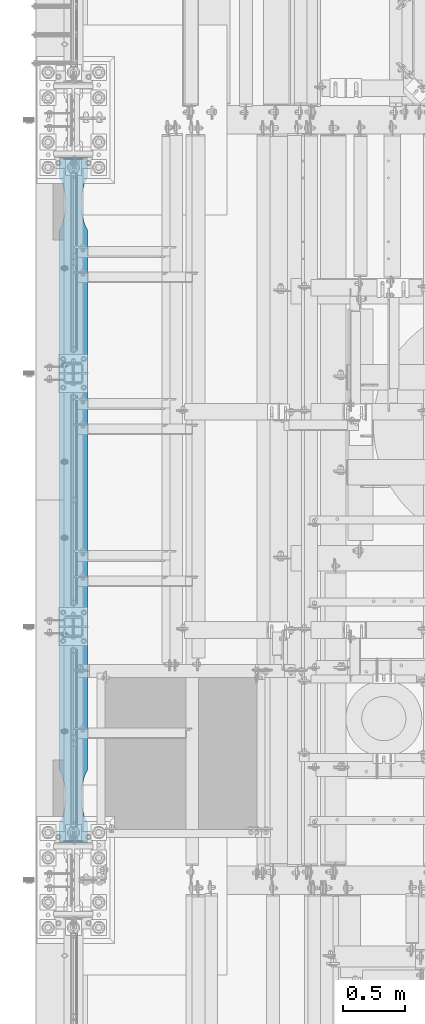
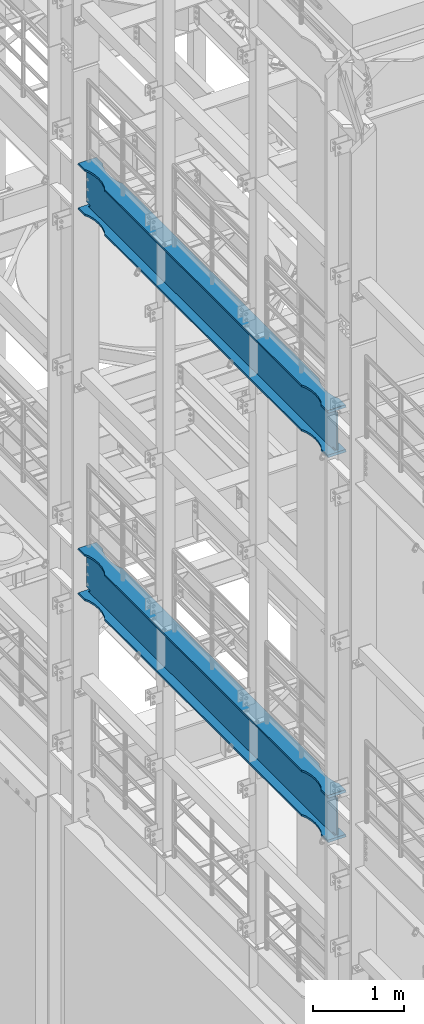
# One storey, part 1021 of 1876: 2 beams, 2 elements without a shape of their own.
"""IFC2X3 building model written with IfcOpenShell, lengths in millimetres."""

from ifc_helpers import new_model, si_unit, frame, origin_with_axes, place, context, subcontext, project, spatial, faceted_brep, material, type_object, element, aggregate, save


model = new_model("IFC2X3")

# Units and contexts
model_context = context("Model", 3, precision=1e-05, world=origin_with_axes())
body_context = subcontext(model_context, "Body", "Model", "MODEL_VIEW")
ifc_project = project(units=[si_unit("LENGTHUNIT", "METRE", prefix="MILLI"), si_unit("AREAUNIT", "SQUARE_METRE"), si_unit("VOLUMEUNIT", "CUBIC_METRE"), si_unit("MASSUNIT", "GRAM", prefix="KILO"), si_unit("TIMEUNIT", "SECOND"), si_unit("PLANEANGLEUNIT", "RADIAN"), si_unit("SOLIDANGLEUNIT", "STERADIAN"), si_unit("THERMODYNAMICTEMPERATUREUNIT", "DEGREE_CELSIUS"), si_unit("LUMINOUSINTENSITYUNIT", "LUMEN")], contexts=[model_context])

# Site, building, storey
site_placement = place(None, origin_with_axes())
site = spatial("IfcSite", under=ifc_project, at=site_placement, CompositionType="ELEMENT")
building_placement = place(site_placement, origin_with_axes())
building = spatial("IfcBuilding", under=site, at=building_placement, Name="Undefined", CompositionType="ELEMENT")
storey_placement = place(building_placement, origin_with_axes())
storey = spatial("IfcBuildingStorey", under=building, at=storey_placement, Name="Undefined", CompositionType="ELEMENT", Elevation=0.0)

# Assembly, beam
assembly_1_placement = place(storey_placement, origin_with_axes())
assembly_1 = element("IfcElementAssembly", 1, at=assembly_1_placement, inside=storey, Name="BEAM", AssemblyPlace="NOTDEFINED", PredefinedType="RIGID_FRAME")
ifc_material = material(Name="STEEL/A992")
beam_type = type_object("IfcBeamType", Name="W24X103", PredefinedType="NOTDEFINED")
beam_1_placement = place(assembly_1_placement, frame((0.0, 1524.0, 12998.45), z_axis=(0.0, 0.0, 1.0), x_axis=(0.0, 1.0, 0.0)))
beam_1 = element("IfcBeam", 2, at=beam_1_placement, type_object=beam_type, material=ifc_material, Name="BEAM", ObjectType="W24X103", context=body_context, shape_type="Brep", body=[
    faceted_brep([(306.3875, 7.14375, -250.825000000001), (298.45, -7.14375, -250.825000000001), (298.45, -7.14375, 250.825000000001), (306.3875, 7.14375, 250.825000000001), (5789.6125, 7.14375, 250.825000000001), (5797.55, -7.14375, 250.825000000001), (5797.55, -7.14375, -250.825000000001), (5789.6125, 7.14375, -250.825000000001), (669.925004774302, 63.4999944716747, -285.75), (669.925004774302, 63.4999944716747, -311.150000000001), (585.563156651265, 69.8863827803352, -311.150000000001), (585.563156651265, 69.8863827803352, -285.75), (754.286852762112, 69.8863845665965, -285.75), (754.286852762112, 69.8863845665965, -311.150000000001), (836.72586171043, 88.899989642473, -285.75), (836.72586171043, 88.899989642473, -311.150000000001), (885.825008761703, 114.299990374483, -285.75), (885.825008761703, 114.3, -311.150000000001), (5210.175, 114.3, -285.75), (5210.175, 114.3, -311.150000000001), (5259.2741470513, 88.8999992679901, -285.75), (5259.2741470513, 88.8999992679901, -311.150000000001), (5341.71315599965, 69.8863941921136, -285.75), (5341.71315599965, 69.8863941921136, -311.150000000001), (5426.0750039875, 63.5000040971918, -285.75), (5426.0750039875, 63.5000040971918, -311.150000000001), (5510.43685211057, 69.8863924058523, -285.75), (5510.43685211057, 69.8863924058523, -311.150000000001), (5592.87586146151, 88.8999957361821, -285.75), (5592.87586146151, 88.8999957361821, -311.150000000001), (5641.97500876196, 114.299992330618, -285.75), (5641.97500876196, 114.3, -311.150000000001), (5782.88540094246, 114.299999277079, -285.75), (5797.55, 114.3, -311.150000000001), (454.024999999921, 114.3, 311.150000000001), (454.024999999921, 114.3, 285.75), (298.45, 114.3, 285.75), (313.114586308271, 114.3, 311.150000000001), (503.124147300347, 88.8999861106649, 311.150000000001), (503.124147300347, 88.8999861106649, 285.75), (585.563156651265, 69.8863827803352, 311.150000000001), (585.563156651265, 69.8863827803352, 285.75), (669.925004774302, 63.4999944716747, 311.150000000001), (669.925004774302, 63.4999944716747, 285.75), (754.286852762112, 69.8863845665965, 311.150000000001), (754.286852762112, 69.8863845665965, 285.75), (836.72586171043, 88.899989642473, 311.150000000001), (836.72586171043, 88.899989642473, 285.75), (885.825008761703, 114.299990374483, 311.150000000001), (885.825008761703, 114.3, 285.75), (5210.175, 114.3, 311.150000000001), (5210.175, 114.3, 285.75), (5259.2741470513, 88.8999992679901, 311.150000000001), (5259.2741470513, 88.8999992679901, 285.75), (5341.71315599965, 69.8863941921136, 311.150000000001), (5341.71315599965, 69.8863941921136, 285.75), (5426.0750039875, 63.5000040971918, 311.150000000001), (5426.0750039875, 63.5000040971918, 285.75), (5510.43685211057, 69.8863924058523, 311.150000000001), (5510.43685211057, 69.8863924058523, 285.75), (5592.87586146151, 88.8999957361821, 311.150000000001), (5592.87586146151, 88.8999957361821, 285.75), (5641.97500876196, 114.299992330618, 311.150000000001), (5641.97500876196, 114.3, 285.75), (5782.88541369173, 114.29999927708, 311.150000000001), (5797.55, 114.3, 285.75), (298.45, 7.14375000000018, 285.75), (5797.55, 7.14375000000018, 285.75), (382.382251149282, -7.14375000000018, -269.000062630286), (382.382251149282, 7.14375000000018, -269.000062630286), (346.909996826172, 7.14375000000018, -285.35299987793), (346.909996826172, -7.14375000000018, -285.35299987793), (386.272459055476, -7.14375000000018, -265.703842989446), (386.272459055476, 7.14375000000018, -265.703842989446), (387.905124802588, -7.14375000000018, -260.873399528195), (387.905124802588, 7.14375000000018, -260.873399528195), (386.81238362386, -7.14375000000018, -255.89296800167), (386.81238362386, 7.14375000000018, -255.89296800167), (383.307376832887, -7.14375000000018, -252.189765486371), (383.307376832887, 7.14375000000018, -252.189765486371), (378.39451650093, -7.14375000000018, -250.825000000001), (378.39451650093, 7.14375000000018, -250.825000000001), (377.559514535493, -7.14375000000018, 250.825000000001), (377.559514535493, 7.14375000000018, 250.825000000001), (382.472374804242, -7.14375000000018, 252.189765448315), (382.472374804242, 7.14375000000018, 252.189765448315), (385.977381589376, -7.14375000000018, 255.892967871263), (385.977381589376, 7.14375000000018, 255.892967871263), (387.070122849314, -7.14375000000018, 260.873399307191), (387.070122849314, 7.14375000000018, 260.873399307191), (385.437457255921, -7.14375000000018, 265.703842745359), (385.437457255921, 7.14375000000018, 265.703842745359), (381.547249518856, -7.14375000000018, 269.000062475843), (381.547249518856, 7.14375000000018, 269.000062475843), (346.074998474121, -7.14375000000018, 285.35299987793), (346.074998474121, 7.14375000000018, 285.35299987793), (298.45, -7.14375000000018, 285.35299987793), (298.45, 7.14375000000018, 285.35299987793), (298.45, -7.14375000000018, 285.75), (5641.97500876196, -114.299992330618, 311.150000000001), (5641.97500876196, -114.3, 285.75), (5797.55, -114.3, 285.75), (5782.88541369173, -114.29999927708, 311.150000000001), (5592.87586146151, -88.8999957361821, 311.150000000001), (5592.87586146151, -88.8999957361821, 285.75), (5510.43685211057, -69.8863924058523, 311.150000000001), (5510.43685211057, -69.8863924058523, 285.75), (5426.0750039875, -63.5000040971918, 311.150000000001), (5426.0750039875, -63.5000040971918, 285.75), (5341.71315599965, -69.8863941921136, 311.150000000001), (5341.71315599965, -69.8863941921136, 285.75), (5259.2741470513, -88.8999992679901, 311.150000000001), (5259.2741470513, -88.8999992679901, 285.75), (5210.175, -114.3, 311.150000000001), (5210.175, -114.3, 285.75), (885.825008761703, -114.300009625517, 311.150000000001), (885.825008761703, -114.3, 285.75), (836.72586171043, -88.9000088935072, 311.150000000001), (836.72586171043, -88.9000088935072, 285.75), (754.286852762112, -69.8864038176307, 311.150000000001), (754.286852762112, -69.8864038176307, 285.75), (669.925004774302, -63.5000137227089, 311.150000000001), (669.925004774302, -63.5000137227089, 285.75), (585.563156651265, -69.8864020313695, 311.150000000001), (585.563156651265, -69.8864020313695, 285.75), (503.124147300347, -88.9000053616992, 311.150000000001), (503.124147300347, -88.9000053616992, 285.75), (454.024999999921, -114.3, 311.150000000001), (454.024999999921, -114.3, 285.75), (313.114586308271, -114.3, 311.150000000001), (298.45, -114.3, 285.75), (5797.55, -7.14375000000018, 285.75), (5797.55, -7.14375000000018, 285.35299987793), (5797.55, 7.14375000000018, 285.35299987793), (5749.92500152588, -7.14375000000018, 285.35299987793), (5749.92500152588, 7.14375000000018, 285.35299987793), (5714.45275048114, -7.14375000000018, 269.000062475843), (5714.45275048114, 7.14375000000018, 269.000062475843), (5710.56254274408, -7.14375000000018, 265.703842745359), (5710.56254274408, 7.14375000000018, 265.703842745359), (5708.92987715069, -7.14375000000018, 260.873399307191), (5708.92987715069, 7.14375000000018, 260.873399307191), (5710.02261841062, -7.14375000000018, 255.892967871263), (5710.02261841062, 7.14375000000018, 255.892967871263), (5713.52762519576, -7.14375000000018, 252.189765448315), (5713.52762519576, 7.14375000000018, 252.189765448315), (5718.44048546451, -7.14375000000018, 250.825000000001), (5718.44048546451, 7.14375000000018, 250.825000000001), (5717.60548349907, -7.14375000000018, -250.825000000001), (5717.60548349907, 7.14375000000018, -250.825000000001), (5712.69262316711, -7.14375000000018, -252.189765486371), (5712.69262316711, 7.14375000000018, -252.189765486371), (5709.18761637614, -7.14375000000018, -255.89296800167), (5709.18761637614, 7.14375000000018, -255.89296800167), (5708.09487519741, -7.14375000000018, -260.873399528195), (5708.09487519741, 7.14375000000018, -260.873399528195), (5709.72754094452, -7.14375000000018, -265.703842989446), (5709.72754094452, 7.14375000000018, -265.703842989446), (5713.61774885072, -7.14375000000018, -269.000062630286), (5713.61774885072, 7.14375000000018, -269.000062630286), (5749.09000317383, -7.14375000000018, -285.35299987793), (5749.09000317383, 7.14375000000018, -285.35299987793), (5782.65620061438, -7.14375000000018, -285.35299987793), (5782.65620061438, 7.14375000000018, -285.35299987793), (5797.55, -114.3, -311.150000000001), (5782.88540094246, 7.14375000000018, -285.75), (5782.88540094246, -7.14375000000018, -285.75), (5782.88540094246, -114.299999277079, -285.75), (5641.97500876196, -114.299992330618, -285.75), (5641.97500876196, -114.3, -311.150000000001), (5592.87586146151, -88.8999957361821, -285.75), (5592.87586146151, -88.8999957361821, -311.150000000001), (5510.43685211057, -69.8863924058523, -285.75), (5510.43685211057, -69.8863924058523, -311.150000000001), (5426.0750039875, -63.5000040971918, -285.75), (5426.0750039875, -63.5000040971918, -311.150000000001), (5341.71315599965, -69.8863941921136, -285.75), (5341.71315599965, -69.8863941921136, -311.150000000001), (5259.2741470513, -88.8999992679901, -285.75), (5259.2741470513, -88.8999992679901, -311.150000000001), (5210.175, -114.3, -285.75), (5210.175, -114.3, -311.150000000001), (885.825008761703, -114.300009625517, -285.75), (885.825008761703, -114.3, -311.150000000001), (836.72586171043, -88.9000088935072, -285.75), (836.72586171043, -88.9000088935072, -311.150000000001), (754.286852762112, -69.8864038176307, -285.75), (754.286852762112, -69.8864038176307, -311.150000000001), (669.925004774302, -63.5000137227089, -285.75), (669.925004774302, -63.5000137227089, -311.150000000001), (585.563156651265, -69.8864020313695, -285.75), (585.563156651265, -69.8864020313695, -311.150000000001), (503.124147300347, -88.9000053616992, -285.75), (503.124147300347, -88.9000053616992, -311.150000000001), (454.024999999921, -114.3, -285.75), (454.024999999921, -114.3, -311.150000000001), (313.11459905754, -114.3, -285.75), (298.45, -114.3, -311.150000000001), (298.45, 114.3, -311.150000000001), (454.024999999921, 114.3, -311.150000000001), (503.124147300347, 88.8999861106649, -311.150000000001), (503.124147300347, 88.8999861106649, -285.75), (454.024999999921, 114.3, -285.75), (313.11459905754, 114.3, -285.75), (313.114599057541, 7.14375000000018, -285.75), (313.343799385621, 7.14375000000018, -285.35299987793), (313.343799385621, -7.14375000000018, -285.35299987793), (313.114599057541, -7.14375000000018, -285.75)], [[[0, 1, 2, 3]], [[4, 5, 6, 7]], [[8, 9, 10, 11]], [[12, 13, 9, 8]], [[14, 15, 13, 12]], [[16, 17, 15, 14]], [[18, 19, 17, 16]], [[20, 21, 19, 18]], [[22, 23, 21, 20]], [[24, 25, 23, 22]], [[26, 27, 25, 24]], [[28, 29, 27, 26]], [[30, 31, 29, 28]], [[31, 30, 32, 33]], [[34, 35, 36, 37]], [[38, 39, 35, 34]], [[40, 41, 39, 38]], [[42, 43, 41, 40]], [[44, 45, 43, 42]], [[46, 47, 45, 44]], [[48, 49, 47, 46]], [[50, 51, 49, 48]], [[52, 53, 51, 50]], [[54, 55, 53, 52]], [[56, 57, 55, 54]], [[58, 59, 57, 56]], [[60, 61, 59, 58]], [[62, 63, 61, 60]], [[63, 62, 64, 65]], [[66, 36, 35, 39, 41, 43, 45, 47, 49, 51, 53, 55, 57, 59, 61, 63, 65, 67]], [[68, 69, 70, 71]], [[72, 73, 69, 68]], [[74, 75, 73, 72]], [[76, 77, 75, 74]], [[78, 79, 77, 76]], [[80, 81, 79, 78]], [[81, 80, 1, 0]], [[82, 83, 3, 2]], [[84, 85, 83, 82]], [[86, 87, 85, 84]], [[88, 89, 87, 86]], [[90, 91, 89, 88]], [[92, 93, 91, 90]], [[94, 95, 93, 92]], [[95, 94, 96, 97]], [[97, 96, 98, 66]], [[99, 100, 101, 102]], [[99, 103, 104, 100]], [[105, 106, 104, 103]], [[107, 108, 106, 105]], [[109, 110, 108, 107]], [[111, 112, 110, 109]], [[113, 114, 112, 111]], [[114, 113, 115, 116]], [[115, 117, 118, 116]], [[119, 120, 118, 117]], [[121, 122, 120, 119]], [[123, 124, 122, 121]], [[125, 126, 124, 123]], [[127, 128, 126, 125]], [[128, 127, 129, 130]], [[100, 104, 106, 108, 110, 112, 114, 116, 118, 120, 122, 124, 126, 128, 130, 98, 131, 101]], [[129, 37, 36, 66, 98, 130]], [[62, 60, 58, 56, 54, 52, 50, 48, 46, 44, 42, 40, 38, 34, 37, 129, 127, 125, 123, 121, 119, 117, 115, 113, 111, 109, 107, 105, 103, 99, 102, 64]], [[101, 131, 67, 65, 64, 102]], [[132, 133, 67, 131]], [[134, 135, 133, 132]], [[136, 137, 135, 134]], [[138, 139, 137, 136]], [[140, 141, 139, 138]], [[142, 143, 141, 140]], [[144, 145, 143, 142]], [[146, 147, 145, 144]], [[147, 146, 5, 4]], [[148, 149, 7, 6]], [[150, 151, 149, 148]], [[152, 153, 151, 150]], [[154, 155, 153, 152]], [[156, 157, 155, 154]], [[158, 159, 157, 156]], [[160, 161, 159, 158]], [[161, 160, 162, 163]], [[164, 33, 32, 165, 163, 162, 166, 167]], [[168, 169, 164, 167]], [[168, 170, 171, 169]], [[172, 173, 171, 170]], [[174, 175, 173, 172]], [[176, 177, 175, 174]], [[178, 179, 177, 176]], [[180, 181, 179, 178]], [[181, 180, 182, 183]], [[182, 184, 185, 183]], [[186, 187, 185, 184]], [[188, 189, 187, 186]], [[190, 191, 189, 188]], [[192, 193, 191, 190]], [[194, 195, 193, 192]], [[195, 194, 196, 197]], [[169, 171, 173, 175, 177, 179, 181, 183, 185, 187, 189, 191, 193, 195, 197, 198, 199, 200, 10, 9, 13, 15, 17, 19, 21, 23, 25, 27, 29, 31, 33, 164]], [[11, 10, 200, 201]], [[30, 28, 26, 24, 22, 20, 18, 16, 14, 12, 8, 11, 201, 202, 203, 204, 165, 32]], [[83, 85, 87, 89, 91, 93, 95, 97, 66, 67, 133, 135, 137, 139, 141, 143, 145, 147, 4, 7, 149, 151, 153, 155, 157, 159, 161, 163, 165, 204, 205, 70, 69, 73, 75, 77, 79, 81, 0, 3]], [[71, 70, 205, 206]], [[160, 158, 156, 154, 152, 150, 148, 6, 5, 146, 144, 142, 140, 138, 136, 134, 132, 131, 98, 96, 94, 92, 90, 88, 86, 84, 82, 2, 1, 80, 78, 76, 74, 72, 68, 71, 206, 207, 166, 162]], [[207, 196, 194, 192, 190, 188, 186, 184, 182, 180, 178, 176, 174, 172, 170, 168, 167, 166]], [[206, 205, 204, 203, 198, 197, 196, 207]], [[202, 199, 198, 203]], [[201, 200, 199, 202]]]),
])
aggregate(assembly_1, [beam_1])

assembly_2_placement = place(storey_placement, origin_with_axes())
assembly_2 = element("IfcElementAssembly", 3, at=assembly_2_placement, inside=storey, Name="BEAM", AssemblyPlace="NOTDEFINED", PredefinedType="RIGID_FRAME")
beam_2_placement = place(assembly_2_placement, frame((0.0, 1524.0, 7842.25), z_axis=(0.0, 0.0, 1.0), x_axis=(0.0, 1.0, 0.0)))
beam_2 = element("IfcBeam", 4, at=beam_2_placement, type_object=beam_type, material=ifc_material, Name="BEAM", ObjectType="W24X103", context=body_context, shape_type="Brep", body=[
    faceted_brep([(306.3875, 7.14375, -250.825000000001), (298.45, -7.14375, -250.825000000001), (298.45, -7.14375, 250.825000000001), (306.3875, 7.14375, 250.825000000001), (5789.6125, 7.14375, 250.825000000001), (5797.55, -7.14375, 250.825000000001), (5797.55, -7.14375, -250.825000000001), (5789.6125, 7.14375, -250.825000000001), (5641.97500876196, 114.299992330618, -285.75), (5641.97500876196, 114.3, -311.150000000001), (5592.87586146151, 88.8999957361821, -311.150000000001), (5592.87586146151, 88.8999957361821, -285.75), (5510.43685211057, 69.8863924058523, -311.150000000001), (5510.43685211057, 69.8863924058523, -285.75), (5426.0750039875, 63.5000040971918, -311.150000000001), (5426.0750039875, 63.5000040971918, -285.75), (5341.71315599965, 69.8863941921136, -311.150000000001), (5341.71315599965, 69.8863941921136, -285.75), (5259.2741470513, 88.8999992679901, -311.150000000001), (5259.2741470513, 88.8999992679901, -285.75), (5210.175, 114.3, -311.150000000001), (5210.175, 114.3, -285.75), (885.825008761703, 114.3, -311.150000000001), (885.825008761703, 114.299990374483, -285.75), (836.72586171043, 88.899989642473, -311.150000000001), (836.72586171043, 88.899989642473, -285.75), (754.286852762112, 69.8863845665965, -311.150000000001), (754.286852762112, 69.8863845665965, -285.75), (669.925004774302, 63.4999944716747, -311.150000000001), (669.925004774302, 63.4999944716747, -285.75), (585.563156651265, 69.8863827803352, -311.150000000001), (585.563156651265, 69.8863827803352, -285.75), (503.124147300347, 88.8999861106649, -311.150000000001), (503.124147300347, 88.8999861106649, -285.75), (454.024999999921, 114.3, -311.150000000001), (454.024999999921, 114.3, -285.75), (298.45, 114.3, -311.150000000001), (313.11459905754, 114.3, -285.75), (5641.97500876196, -114.299992330618, -285.75), (5592.87586146151, -88.8999957361821, -285.75), (5592.87586146151, -88.8999957361821, -311.150000000001), (5641.97500876196, -114.3, -311.150000000001), (5510.43685211057, -69.8863924058523, -285.75), (5510.43685211057, -69.8863924058523, -311.150000000001), (5426.0750039875, -63.5000040971918, -285.75), (5426.0750039875, -63.5000040971918, -311.150000000001), (5341.71315599965, -69.8863941921136, -285.75), (5341.71315599965, -69.8863941921136, -311.150000000001), (5259.2741470513, -88.8999992679901, -285.75), (5259.2741470513, -88.8999992679901, -311.150000000001), (5210.175, -114.3, -285.75), (5210.175, -114.3, -311.150000000001), (885.825008761703, -114.300009625517, -285.75), (885.825008761703, -114.3, -311.150000000001), (836.72586171043, -88.9000088935072, -285.75), (836.72586171043, -88.9000088935072, -311.150000000001), (754.286852762112, -69.8864038176307, -285.75), (754.286852762112, -69.8864038176307, -311.150000000001), (669.925004774302, -63.5000137227089, -285.75), (669.925004774302, -63.5000137227089, -311.150000000001), (585.563156651265, -69.8864020313695, -285.75), (585.563156651265, -69.8864020313695, -311.150000000001), (503.124147300347, -88.9000053616992, -285.75), (503.124147300347, -88.9000053616992, -311.150000000001), (454.024999999921, -114.3, -285.75), (454.024999999921, -114.3, -311.150000000001), (313.11459905754, -114.3, -285.75), (298.45, -114.3, -311.150000000001), (313.343799385621, -7.14375000000018, -285.35299987793), (313.343799385621, 7.14375000000018, -285.35299987793), (313.114599057541, 7.14375000000018, -285.75), (313.114599057541, -7.14375000000018, -285.75), (346.909996826172, -7.14375000000018, -285.35299987793), (346.909996826172, 7.14375000000018, -285.35299987793), (382.382251149282, -7.14375000000018, -269.000062630286), (382.382251149282, 7.14375000000018, -269.000062630286), (386.272459055476, -7.14375000000018, -265.703842989446), (386.272459055476, 7.14375000000018, -265.703842989446), (387.905124802588, -7.14375000000018, -260.873399528195), (387.905124802588, 7.14375000000018, -260.873399528195), (386.81238362386, -7.14375000000018, -255.89296800167), (386.81238362386, 7.14375000000018, -255.89296800167), (383.307376832887, -7.14375000000018, -252.189765486371), (383.307376832887, 7.14375000000018, -252.189765486371), (378.39451650093, -7.14375000000018, -250.825000000001), (378.39451650093, 7.14375000000018, -250.825000000001), (377.559514535493, -7.14375000000018, 250.825000000001), (377.559514535493, 7.14375000000018, 250.825000000001), (382.472374804242, -7.14375000000018, 252.189765448315), (382.472374804242, 7.14375000000018, 252.189765448315), (385.977381589376, -7.14375000000018, 255.892967871263), (385.977381589376, 7.14375000000018, 255.892967871263), (387.070122849314, -7.14375000000018, 260.873399307191), (387.070122849314, 7.14375000000018, 260.873399307191), (385.437457255921, -7.14375000000018, 265.703842745359), (385.437457255921, 7.14375000000018, 265.703842745359), (381.547249518856, -7.14375000000018, 269.000062475843), (381.547249518856, 7.14375000000018, 269.000062475843), (346.074998474121, -7.14375000000018, 285.35299987793), (346.074998474121, 7.14375000000018, 285.35299987793), (298.45, -7.14375000000018, 285.35299987793), (298.45, 7.14375000000018, 285.35299987793), (454.024999999921, 114.3, 311.150000000001), (454.024999999921, 114.3, 285.75), (298.45, 114.3, 285.75), (313.114586308271, 114.3, 311.150000000001), (503.124147300347, 88.8999861106649, 311.150000000001), (503.124147300347, 88.8999861106649, 285.75), (585.563156651265, 69.8863827803352, 311.150000000001), (585.563156651265, 69.8863827803352, 285.75), (669.925004774302, 63.4999944716747, 311.150000000001), (669.925004774302, 63.4999944716747, 285.75), (754.286852762112, 69.8863845665965, 311.150000000001), (754.286852762112, 69.8863845665965, 285.75), (836.72586171043, 88.899989642473, 311.150000000001), (836.72586171043, 88.899989642473, 285.75), (885.825008761703, 114.299990374483, 311.150000000001), (885.825008761703, 114.3, 285.75), (5210.175, 114.3, 311.150000000001), (5210.175, 114.3, 285.75), (5259.2741470513, 88.8999992679901, 311.150000000001), (5259.2741470513, 88.8999992679901, 285.75), (5341.71315599965, 69.8863941921136, 311.150000000001), (5341.71315599965, 69.8863941921136, 285.75), (5426.0750039875, 63.5000040971918, 311.150000000001), (5426.0750039875, 63.5000040971918, 285.75), (5510.43685211057, 69.8863924058523, 311.150000000001), (5510.43685211057, 69.8863924058523, 285.75), (5592.87586146151, 88.8999957361821, 311.150000000001), (5592.87586146151, 88.8999957361821, 285.75), (5641.97500876196, 114.299992330618, 311.150000000001), (5641.97500876196, 114.3, 285.75), (5782.88541369173, 114.29999927708, 311.150000000001), (5797.55, 114.3, 285.75), (298.45, 7.14375000000018, 285.75), (5797.55, 7.14375000000018, 285.75), (5797.55, -7.14375000000018, 285.35299987793), (5797.55, 7.14375000000018, 285.35299987793), (5797.55, -7.14375000000018, 285.75), (5749.92500152588, -7.14375000000018, 285.35299987793), (5749.92500152588, 7.14375000000018, 285.35299987793), (5714.45275048114, -7.14375000000018, 269.000062475843), (5714.45275048114, 7.14375000000018, 269.000062475843), (5710.56254274408, -7.14375000000018, 265.703842745359), (5710.56254274408, 7.14375000000018, 265.703842745359), (5708.92987715069, -7.14375000000018, 260.873399307191), (5708.92987715069, 7.14375000000018, 260.873399307191), (5710.02261841062, -7.14375000000018, 255.892967871263), (5710.02261841062, 7.14375000000018, 255.892967871263), (5713.52762519576, -7.14375000000018, 252.189765448315), (5713.52762519576, 7.14375000000018, 252.189765448315), (5718.44048546451, -7.14375000000018, 250.825000000001), (5718.44048546451, 7.14375000000018, 250.825000000001), (5717.60548349907, -7.14375000000018, -250.825000000001), (5717.60548349907, 7.14375000000018, -250.825000000001), (5712.69262316711, -7.14375000000018, -252.189765486371), (5712.69262316711, 7.14375000000018, -252.189765486371), (5709.18761637614, -7.14375000000018, -255.89296800167), (5709.18761637614, 7.14375000000018, -255.89296800167), (5708.09487519741, -7.14375000000018, -260.873399528195), (5708.09487519741, 7.14375000000018, -260.873399528195), (5709.72754094452, -7.14375000000018, -265.703842989446), (5709.72754094452, 7.14375000000018, -265.703842989446), (5713.61774885072, -7.14375000000018, -269.000062630286), (5713.61774885072, 7.14375000000018, -269.000062630286), (5749.09000317383, -7.14375000000018, -285.35299987793), (5749.09000317383, 7.14375000000018, -285.35299987793), (5782.65620061438, -7.14375000000018, -285.35299987793), (5782.65620061438, 7.14375000000018, -285.35299987793), (5782.88540094246, 7.14375000000018, -285.75), (5782.88540094246, 114.299999277079, -285.75), (5797.55, 114.3, -311.150000000001), (5797.55, -114.3, -311.150000000001), (5782.88540094246, -114.299999277079, -285.75), (5782.88540094246, -7.14375000000018, -285.75), (298.45, -7.14375000000018, 285.75), (313.114586308271, -114.3, 311.150000000001), (298.45, -114.3, 285.75), (454.024999999921, -114.3, 285.75), (454.024999999921, -114.3, 311.150000000001), (503.124147300347, -88.9000053616992, 285.75), (503.124147300347, -88.9000053616992, 311.150000000001), (585.563156651265, -69.8864020313695, 285.75), (585.563156651265, -69.8864020313695, 311.150000000001), (669.925004774302, -63.5000137227089, 285.75), (669.925004774302, -63.5000137227089, 311.150000000001), (754.286852762112, -69.8864038176307, 285.75), (754.286852762112, -69.8864038176307, 311.150000000001), (836.72586171043, -88.9000088935072, 285.75), (836.72586171043, -88.9000088935072, 311.150000000001), (885.825008761703, -114.300009625517, 311.150000000001), (885.825008761703, -114.3, 285.75), (5210.175, -114.3, 285.75), (5210.175, -114.3, 311.150000000001), (5259.2741470513, -88.8999992679901, 285.75), (5259.2741470513, -88.8999992679901, 311.150000000001), (5341.71315599965, -69.8863941921136, 285.75), (5341.71315599965, -69.8863941921136, 311.150000000001), (5426.0750039875, -63.5000040971918, 285.75), (5426.0750039875, -63.5000040971918, 311.150000000001), (5510.43685211057, -69.8863924058523, 285.75), (5510.43685211057, -69.8863924058523, 311.150000000001), (5592.87586146151, -88.8999957361821, 285.75), (5592.87586146151, -88.8999957361821, 311.150000000001), (5641.97500876196, -114.299992330618, 311.150000000001), (5641.97500876196, -114.3, 285.75), (5797.55, -114.3, 285.75), (5782.88541369173, -114.29999927708, 311.150000000001)], [[[0, 1, 2, 3]], [[4, 5, 6, 7]], [[8, 9, 10, 11]], [[11, 10, 12, 13]], [[13, 12, 14, 15]], [[15, 14, 16, 17]], [[17, 16, 18, 19]], [[19, 18, 20, 21]], [[21, 20, 22, 23]], [[23, 22, 24, 25]], [[25, 24, 26, 27]], [[27, 26, 28, 29]], [[29, 28, 30, 31]], [[31, 30, 32, 33]], [[33, 32, 34, 35]], [[35, 34, 36, 37]], [[38, 39, 40, 41]], [[42, 43, 40, 39]], [[44, 45, 43, 42]], [[46, 47, 45, 44]], [[48, 49, 47, 46]], [[50, 51, 49, 48]], [[51, 50, 52, 53]], [[52, 54, 55, 53]], [[56, 57, 55, 54]], [[58, 59, 57, 56]], [[60, 61, 59, 58]], [[62, 63, 61, 60]], [[64, 65, 63, 62]], [[65, 64, 66, 67]], [[68, 69, 70, 37, 36, 67, 66, 71]], [[72, 73, 69, 68]], [[74, 75, 73, 72]], [[76, 77, 75, 74]], [[78, 79, 77, 76]], [[80, 81, 79, 78]], [[82, 83, 81, 80]], [[84, 85, 83, 82]], [[85, 84, 1, 0]], [[86, 87, 3, 2]], [[88, 89, 87, 86]], [[90, 91, 89, 88]], [[92, 93, 91, 90]], [[94, 95, 93, 92]], [[96, 97, 95, 94]], [[98, 99, 97, 96]], [[99, 98, 100, 101]], [[102, 103, 104, 105]], [[106, 107, 103, 102]], [[108, 109, 107, 106]], [[110, 111, 109, 108]], [[112, 113, 111, 110]], [[114, 115, 113, 112]], [[116, 117, 115, 114]], [[118, 119, 117, 116]], [[120, 121, 119, 118]], [[122, 123, 121, 120]], [[124, 125, 123, 122]], [[126, 127, 125, 124]], [[128, 129, 127, 126]], [[130, 131, 129, 128]], [[131, 130, 132, 133]], [[134, 104, 103, 107, 109, 111, 113, 115, 117, 119, 121, 123, 125, 127, 129, 131, 133, 135]], [[136, 137, 135, 138]], [[139, 140, 137, 136]], [[141, 142, 140, 139]], [[143, 144, 142, 141]], [[145, 146, 144, 143]], [[147, 148, 146, 145]], [[149, 150, 148, 147]], [[151, 152, 150, 149]], [[152, 151, 5, 4]], [[153, 154, 7, 6]], [[155, 156, 154, 153]], [[157, 158, 156, 155]], [[159, 160, 158, 157]], [[161, 162, 160, 159]], [[163, 164, 162, 161]], [[165, 166, 164, 163]], [[166, 165, 167, 168]], [[87, 89, 91, 93, 95, 97, 99, 101, 134, 135, 137, 140, 142, 144, 146, 148, 150, 152, 4, 7, 154, 156, 158, 160, 162, 164, 166, 168, 169, 70, 69, 73, 75, 77, 79, 81, 83, 85, 0, 3]], [[8, 11, 13, 15, 17, 19, 21, 23, 25, 27, 29, 31, 33, 35, 37, 70, 169, 170]], [[9, 8, 170, 171]], [[41, 40, 43, 45, 47, 49, 51, 53, 55, 57, 59, 61, 63, 65, 67, 36, 34, 32, 30, 28, 26, 24, 22, 20, 18, 16, 14, 12, 10, 9, 171, 172]], [[38, 41, 172, 173]], [[71, 66, 64, 62, 60, 58, 56, 54, 52, 50, 48, 46, 44, 42, 39, 38, 173, 174]], [[172, 171, 170, 169, 168, 167, 174, 173]], [[165, 163, 161, 159, 157, 155, 153, 6, 5, 151, 149, 147, 145, 143, 141, 139, 136, 138, 175, 100, 98, 96, 94, 92, 90, 88, 86, 2, 1, 84, 82, 80, 78, 76, 74, 72, 68, 71, 174, 167]], [[101, 100, 175, 134]], [[176, 105, 104, 134, 175, 177]], [[178, 179, 176, 177]], [[179, 178, 180, 181]], [[181, 180, 182, 183]], [[183, 182, 184, 185]], [[185, 184, 186, 187]], [[187, 186, 188, 189]], [[190, 189, 188, 191]], [[192, 193, 190, 191]], [[193, 192, 194, 195]], [[195, 194, 196, 197]], [[197, 196, 198, 199]], [[199, 198, 200, 201]], [[201, 200, 202, 203]], [[204, 205, 206, 207]], [[130, 128, 126, 124, 122, 120, 118, 116, 114, 112, 110, 108, 106, 102, 105, 176, 179, 181, 183, 185, 187, 189, 190, 193, 195, 197, 199, 201, 203, 204, 207, 132]], [[206, 138, 135, 133, 132, 207]], [[205, 202, 200, 198, 196, 194, 192, 191, 188, 186, 184, 182, 180, 178, 177, 175, 138, 206]], [[204, 203, 202, 205]]]),
])
aggregate(assembly_2, [beam_2])

save(model, "model.ifc")
